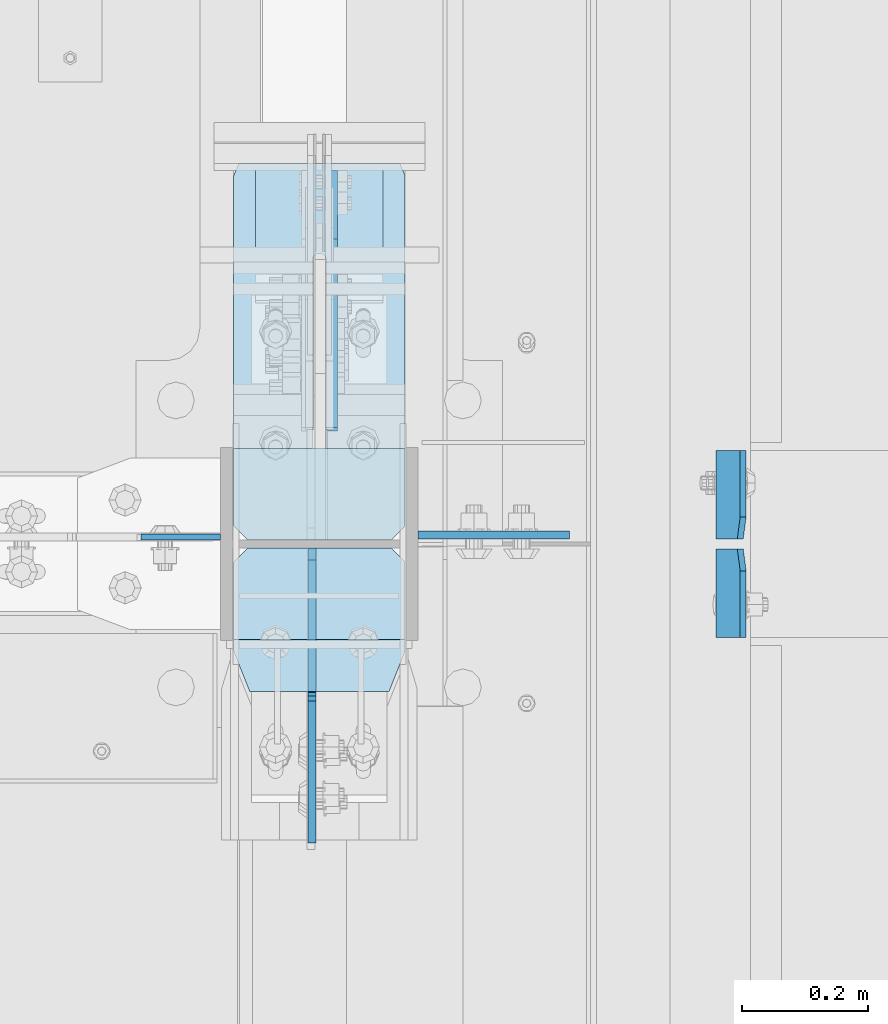
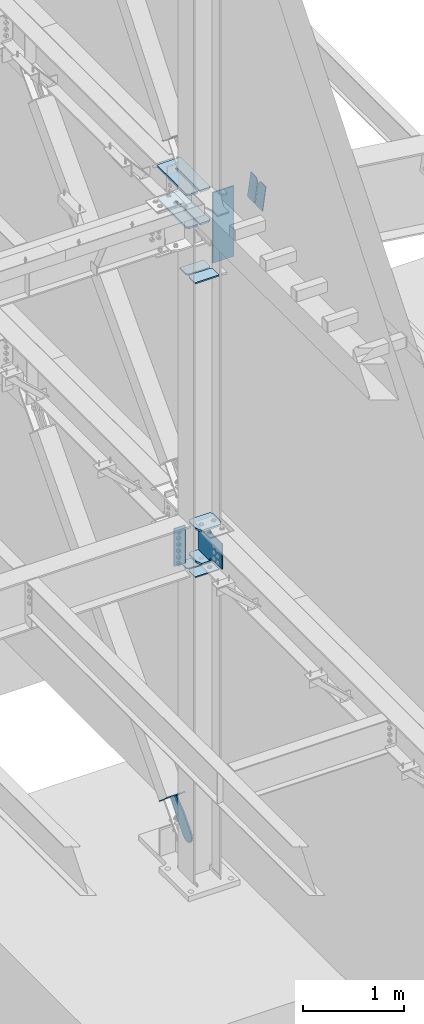
# One storey, part 1046 of 1179: 15 plates, 4 elements without a shape of their own.
"""IFC2X3 building model written with IfcOpenShell, lengths in millimetres."""

import ifcopenshell
import ifcopenshell.guid

model = None  # the IFC model being written
_history = None  # IfcOwnerHistory: only IFC2X3 demands one
_inside = {}  # id of a spatial element -> (the spatial element, [elements in it])
_under = {}  # id of a project, library or spatial element -> (it, [spatial elements below it])
_declared = {}  # id of a project -> (the project, [libraries it declares])
_typed = {}  # id of a type object -> (the type object, [elements of that type])
_made_of = {}  # id of a material, layer set ... -> (it, [elements and type objects made of it])


def new_model(schema):
    """Start an empty IFC model of exactly this schema.

    Asked for "IFC4X3", IfcOpenShell would pick the latest addendum, in which some entities
    have other attributes; the version numbers below select the first issue.
    IFC2X3 requires an IfcOwnerHistory on every rooted entity: one is made here for all.
    """
    global model, _history
    if schema == "IFC4X3":
        model = ifcopenshell.file(schema_version=(4, 3, 0, 0))
    else:
        model = ifcopenshell.file(schema=schema)
    _inside.clear()
    _under.clear()
    _declared.clear()
    _typed.clear()
    _made_of.clear()
    _history = None
    if model.schema == "IFC2X3":
        org = make("IfcOrganization", Name="unknown")
        user = make(
            "IfcPersonAndOrganization",
            ThePerson=make("IfcPerson", FamilyName="unknown"),
            TheOrganization=org,
        )
        app = make(
            "IfcApplication",
            ApplicationDeveloper=org,
            Version="unknown",
            ApplicationFullName="unknown",
            ApplicationIdentifier="unknown",
        )
        _history = make(
            "IfcOwnerHistory",
            OwningUser=user,
            OwningApplication=app,
            ChangeAction="ADDED",
            CreationDate=0,
        )
    return model


def make(cls, **values):
    """One entity of the class cls with the attributes given. An attribute that is None is left unset."""
    return model.create_entity(
        cls, **{name: value for name, value in values.items() if value is not None}
    )


def rooted(cls, **values):
    """An entity with a GlobalId (a new one), such as an element, a storey or a relation."""
    return make(cls, GlobalId=ifcopenshell.guid.new(), OwnerHistory=_history, **values)


def si_unit(unit_type, name, prefix=None):
    """IfcSIUnit, for example si_unit("LENGTHUNIT", "METRE", prefix="MILLI")."""
    return make("IfcSIUnit", UnitType=unit_type, Prefix=prefix, Name=name)


def assignment(units):
    """IfcUnitAssignment: the units of a project."""
    return None if units is None else make("IfcUnitAssignment", Units=units)


def point(xyz):
    """IfcCartesianPoint."""
    return None if xyz is None else make("IfcCartesianPoint", Coordinates=xyz)


def direction(xyz):
    """IfcDirection."""
    return None if xyz is None else make("IfcDirection", DirectionRatios=xyz)


def frame(location, z_axis=None, x_axis=None):
    """IfcAxis2Placement3D, a coordinate frame: its origin and axes. An axis left out is left unset."""
    return make(
        "IfcAxis2Placement3D",
        Location=point(location),
        Axis=direction(z_axis),
        RefDirection=direction(x_axis),
    )


def origin_with_axes():
    """The frame at (0, 0, 0) with the z axis (0, 0, 1) and the x axis (1, 0, 0) written out."""
    return frame((0.0, 0.0, 0.0), z_axis=(0.0, 0.0, 1.0), x_axis=(1.0, 0.0, 0.0))


def place(relative_to, where):
    """IfcLocalPlacement: puts the frame where relative to a parent placement (None: the world)."""
    return make(
        "IfcLocalPlacement", PlacementRelTo=relative_to, RelativePlacement=where
    )


def context(
    kind, dimensions, precision=None, world=None, true_north=None, identifier=None
):
    """IfcGeometricRepresentationContext, for example the 3D "Model" context."""
    return make(
        "IfcGeometricRepresentationContext",
        ContextIdentifier=identifier,
        ContextType=kind,
        CoordinateSpaceDimension=dimensions,
        Precision=precision,
        WorldCoordinateSystem=world,
        TrueNorth=true_north,
    )


def subcontext(parent, identifier, kind, view, scale=None):
    """IfcGeometricRepresentationSubContext, for example "Body" below "Model"."""
    return make(
        "IfcGeometricRepresentationSubContext",
        ContextIdentifier=identifier,
        ContextType=kind,
        ParentContext=parent,
        TargetScale=scale,
        TargetView=view,
    )


def project(units=None, contexts=None):
    """IfcProject with its units and contexts."""
    return rooted(
        "IfcProject",
        Name="project",
        RepresentationContexts=contexts,
        UnitsInContext=assignment(units),
    )


def spatial(cls, under=None, at=None, **own):
    """A site, building, storey or space (cls), placed at a placement, below another one or the project."""
    s = rooted(cls, ObjectPlacement=at, **own)
    if under is not None:
        _under.setdefault(under.id(), (under, []))[1].append(s)
    return s


def faces_of(points, faces, orient=None, outer=None):
    """IfcFace entities. A face is a list of loops; a loop is a list of indices into points, from 0.

    orient and outer hold one flag for each loop. By default every Orientation is true, the
    first loop of a face is its IfcFaceOuterBound and the others are IfcFaceBound.
    """
    made = []
    for i, loops in enumerate(faces):
        bounds = []
        for j, loop in enumerate(loops):
            is_outer = j == 0 if outer is None else outer[i][j]
            bounds.append(
                make(
                    "IfcFaceOuterBound" if is_outer else "IfcFaceBound",
                    Bound=make("IfcPolyLoop", Polygon=[points[k] for k in loop]),
                    Orientation=True if orient is None else orient[i][j],
                )
            )
        made.append(make("IfcFace", Bounds=bounds))
    return made


def faceted_brep(points, faces, orient=None, outer=None, voids=None):
    """IfcFacetedBrep: a solid bounded by flat faces; with voids (closed shells), ...WithVoids."""
    shared = [point(p) for p in points]
    hull = make("IfcClosedShell", CfsFaces=faces_of(shared, faces, orient, outer))
    if voids is None:
        return make("IfcFacetedBrep", Outer=hull)
    return make(
        "IfcFacetedBrepWithVoids",
        Outer=hull,
        Voids=[
            make(cls, CfsFaces=faces_of(shared, fs, o, b)) for cls, fs, o, b in voids
        ],
    )


def shape(context_of_items, identifier, shape_type, items):
    """IfcShapeRepresentation: the items that make up one representation, for example the "Body"."""
    return make(
        "IfcShapeRepresentation",
        ContextOfItems=context_of_items,
        RepresentationIdentifier=identifier,
        RepresentationType=shape_type,
        Items=items,
    )


def material(Name=None, Category=None):
    """IfcMaterial."""
    return make("IfcMaterial", Name=Name, Category=Category)


def made_of(thing, what):
    """Note that an element or type object is made of a material, layer set ...; save() writes the relation."""
    if what is not None:
        _made_of.setdefault(what.id(), (what, []))[1].append(thing)
    return thing


def type_object(cls, material=None, **own):
    """A type object (cls), such as IfcWallType, which elements share."""
    return made_of(rooted(cls, **own), material)


def element(
    cls,
    number,
    at=None,
    inside=None,
    cuts=None,
    type_object=None,
    material=None,
    context=None,
    identifier="Body",
    shape_type=None,
    held_by="IfcProductDefinitionShape",
    body=None,
    shapes=None,
    **own,
):
    """One element of the class cls, such as IfcWall. Its Tag is "e" and its number.

    at: its placement. inside: the storey or other place that contains it. cuts: it is an
    opening in that element (IfcRelVoidsElement). A single representation is given by context,
    identifier, shape_type and body (its items); several are given by shapes. held_by: the class
    of the entity that holds the representations. save() writes the other relations.
    """
    e = rooted(cls, Tag="e%d" % number, ObjectPlacement=at, **own)
    if body is not None:
        shapes = [shape(context, identifier, shape_type, body)]
    if shapes is not None:
        e.Representation = make(held_by, Representations=shapes)
    if inside is not None:
        _inside.setdefault(inside.id(), (inside, []))[1].append(e)
    if cuts is not None:
        rooted(
            "IfcRelVoidsElement", RelatingBuildingElement=cuts, RelatedOpeningElement=e
        )
    if type_object is not None:
        _typed.setdefault(type_object.id(), (type_object, []))[1].append(e)
    return made_of(e, material)


def aggregate(whole, parts):
    """IfcRelAggregates: a whole, such as a stair, and the parts it consists of."""
    return rooted("IfcRelAggregates", RelatingObject=whole, RelatedObjects=parts)


def save(model, path):
    """Write the relations noted so far, then the file.

    IfcRelAggregates (storeys below a building ...), IfcRelContainedInSpatialStructure (elements
    in a storey), IfcRelDefinesByType, IfcRelAssociatesMaterial and IfcRelDeclares: one each for
    every whole, place, type object, material and project.
    """
    for whole, parts in _under.values():
        aggregate(whole, parts)
    for where, things in _inside.values():
        rooted(
            "IfcRelContainedInSpatialStructure",
            RelatedElements=things,
            RelatingStructure=where,
        )
    for kind, things in _typed.values():
        rooted("IfcRelDefinesByType", RelatedObjects=things, RelatingType=kind)
    for what, things in _made_of.values():
        rooted("IfcRelAssociatesMaterial", RelatedObjects=things, RelatingMaterial=what)
    for by, libraries in _declared.values():
        rooted("IfcRelDeclares", RelatingContext=by, RelatedDefinitions=libraries)
    model.write(path)


model = new_model("IFC2X3")

# Units and contexts
model_context = context("Model", 3, precision=1e-05, world=origin_with_axes())
body_context = subcontext(model_context, "Body", "Model", "MODEL_VIEW")
ifc_project = project(units=[si_unit("LENGTHUNIT", "METRE", prefix="MILLI"), si_unit("AREAUNIT", "SQUARE_METRE"), si_unit("VOLUMEUNIT", "CUBIC_METRE"), si_unit("MASSUNIT", "GRAM", prefix="KILO"), si_unit("TIMEUNIT", "SECOND"), si_unit("PLANEANGLEUNIT", "RADIAN"), si_unit("SOLIDANGLEUNIT", "STERADIAN"), si_unit("THERMODYNAMICTEMPERATUREUNIT", "DEGREE_CELSIUS"), si_unit("LUMINOUSINTENSITYUNIT", "LUMEN")], contexts=[model_context])

# Site, building, storey
site_placement = place(None, origin_with_axes())
site = spatial("IfcSite", under=ifc_project, at=site_placement, CompositionType="ELEMENT")
building_placement = place(site_placement, origin_with_axes())
building = spatial("IfcBuilding", under=site, at=building_placement, Name="Undefined", CompositionType="ELEMENT")
storey_placement = place(building_placement, origin_with_axes())
storey = spatial("IfcBuildingStorey", under=building, at=storey_placement, Name="Undefined", CompositionType="ELEMENT", Elevation=0.0)

# Assembly, plates
assembly_1_placement = place(storey_placement, origin_with_axes())
assembly_1 = element("IfcElementAssembly", 1, at=assembly_1_placement, inside=storey, Name="COLUMN", AssemblyPlace="NOTDEFINED", PredefinedType="RIGID_FRAME")
ifc_material_1 = material(Name="STEEL/A36")
plate_type_1 = type_object("IfcPlateType", PredefinedType="NOTDEFINED")
plate_1_placement = place(assembly_1_placement, frame((24150.6375, 27062.1125, 4038.6), z_axis=(-1.0, 0.0, 0.0), x_axis=(0.0, 0.0, -1.0)))
plate_1 = element("IfcPlate", 2, at=plate_1_placement, type_object=plate_type_1, material=ifc_material_1, Name="PLATE", context=body_context, shape_type="Brep", body=[
    faceted_brep([(0.0, -4.76249999999709, 0.0), (0.0, -4.76249999999709, 127.0), (0.0, 4.76249999999709, 127.0), (0.0, 4.76249999999709, 0.0), (457.200012207031, -4.76250000000073, 127.0), (457.200012207031, 4.76250000000073, 127.0), (457.200012207031, -4.76250000000073, 0.0), (457.200012207031, 4.76250000000073, 0.0)], [[[0, 1, 2, 3]], [[1, 4, 5, 2]], [[4, 6, 7, 5]], [[6, 0, 3, 7]], [[5, 7, 3, 2]], [[6, 4, 1, 0]]]),
])
ifc_material_2 = material(Name="STEEL/A572-GR.50")
plate_type_2 = type_object("IfcPlateType", PredefinedType="NOTDEFINED")
plate_2_placement = place(assembly_1_placement, frame((24171.2749938965, 27656.8088209119, 7605.7125), z_axis=(0.0, -1.0, 0.0), x_axis=(1.0, 0.0, 0.0)))
plate_2 = element("IfcPlate", 3, at=plate_2_placement, type_object=plate_type_2, material=ifc_material_2, Name="PLATE", context=body_context, shape_type="Brep", body=[
    faceted_brep([(125.412506103512, -11.1125000000002, 599.458820911852), (125.412487792968, -11.1125000000002, 153.987500190735), (125.412487792968, 11.1125000000002, 153.987500190735), (125.412506103512, 11.1125000000002, 599.458820911852), (126.258376502454, -11.1125000000002, 149.734930475586), (126.258376502454, 11.1125000000002, 149.734930475586), (128.667263742896, -11.1125000000002, 146.12977594993), (128.667263742896, 11.1125000000002, 146.12977594993), (132.272418268556, -11.1125000000002, 143.720888709488), (132.272418268556, 11.1125000000002, 143.720888709488), (136.524987602239, -11.1125000000002, 142.875), (136.524987602239, 11.1125000000002, 142.875), (140.777557317386, -11.1125000000002, 143.720888709488), (140.777557317386, 11.1125000000002, 143.720888709488), (144.382711843045, -11.1125000000002, 146.12977594993), (144.382711843045, 11.1125000000002, 146.12977594993), (146.791599083488, -11.1125000000002, 149.734930475586), (146.791599083488, 11.1125000000002, 149.734930475586), (147.637487792974, -11.1125000000002, 153.987500190735), (147.637487792974, 11.1125000000002, 153.987500190735), (147.637506103518, -11.1125000000002, 599.458820911852), (147.637506103518, 11.1125000000002, 599.458820911852), (0.0, -11.1125000000002, 577.233820530382), (22.2250003814697, -11.1125000000002, 599.458820911852), (22.2250003814697, 11.1125000000002, 599.458820911852), (0.0, 11.1125000000002, 577.233820530382), (0.0, -11.1125000000002, 19.0499992370605), (0.0, 11.1125000000002, 19.0499992370605), (7.9375, -11.1125000000002, 0.0), (7.9375, 11.1125000000002, 0.0), (265.112506103513, -11.1125000000002, 0.0), (265.112506103513, 11.1125000000002, 0.0), (273.050006103513, -11.1125000000002, 19.0499992370605), (273.050006103513, 11.1125000000002, 19.0499992370605), (273.050006103513, -11.1125000000002, 577.233820530382), (273.050006103513, 11.1125000000002, 577.233820530382), (250.825005722043, -11.1125000000002, 599.458820911852), (250.825005722043, 11.1125000000002, 599.458820911852)], [[[0, 1, 2, 3]], [[4, 5, 2, 1]], [[6, 7, 5, 4]], [[8, 9, 7, 6]], [[10, 11, 9, 8]], [[12, 13, 11, 10]], [[14, 15, 13, 12]], [[16, 17, 15, 14]], [[18, 19, 17, 16]], [[20, 21, 19, 18]], [[22, 23, 24, 25]], [[26, 22, 25, 27]], [[28, 26, 27, 29]], [[30, 28, 29, 31]], [[32, 30, 31, 33]], [[34, 32, 33, 35]], [[36, 34, 35, 37]], [[16, 14, 12, 10, 8, 6, 4, 1, 0, 23, 22, 26, 28, 30, 32, 34, 36, 20, 18]], [[24, 23, 0, 3]], [[37, 35, 33, 31, 29, 27, 25, 24, 3, 2, 5, 7, 9, 11, 13, 15, 17, 19, 21]], [[36, 37, 21, 20]]]),
])
plate_3_placement = place(assembly_1_placement, frame((24171.2749938965, 27656.8088209119, 8002.5875), z_axis=(0.0, -1.0, 0.0), x_axis=(1.0, 0.0, 0.0)))
plate_3 = element("IfcPlate", 4, at=plate_3_placement, type_object=plate_type_2, material=ifc_material_2, Name="PLATE", context=body_context, shape_type="Brep", body=[
    faceted_brep([(125.412506103512, -11.1125000000002, 599.458820911852), (125.412487792968, -11.1125000000002, 153.987500190735), (125.412487792968, 11.1125000000002, 153.987500190735), (125.412506103512, 11.1125000000002, 599.458820911852), (126.258376502454, -11.1125000000002, 149.734930475586), (126.258376502454, 11.1125000000002, 149.734930475586), (128.667263742896, -11.1125000000002, 146.12977594993), (128.667263742896, 11.1125000000002, 146.12977594993), (132.272418268556, -11.1125000000002, 143.720888709488), (132.272418268556, 11.1125000000002, 143.720888709488), (136.524987602239, -11.1125000000002, 142.875), (136.524987602239, 11.1125000000002, 142.875), (140.777557317386, -11.1125000000002, 143.720888709488), (140.777557317386, 11.1125000000002, 143.720888709488), (144.382711843045, -11.1125000000002, 146.12977594993), (144.382711843045, 11.1125000000002, 146.12977594993), (146.791599083488, -11.1125000000002, 149.734930475586), (146.791599083488, 11.1125000000002, 149.734930475586), (147.637487792974, -11.1125000000002, 153.987500190735), (147.637487792974, 11.1125000000002, 153.987500190735), (147.637506103518, -11.1125000000002, 599.458820911852), (147.637506103518, 11.1125000000002, 599.458820911852), (0.0, -11.1125000000002, 577.233820530382), (22.2250003814697, -11.1125000000002, 599.458820911852), (22.2250003814697, 11.1125000000002, 599.458820911852), (0.0, 11.1125000000002, 577.233820530382), (0.0, -11.1125000000002, 19.0499992370605), (0.0, 11.1125000000002, 19.0499992370605), (7.9375, -11.1125000000002, 0.0), (7.9375, 11.1125000000002, 0.0), (265.112506103513, -11.1125000000002, 0.0), (265.112506103513, 11.1125000000002, 0.0), (273.050006103513, -11.1125000000002, 19.0499992370605), (273.050006103513, 11.1125000000002, 19.0499992370605), (273.050006103513, -11.1125000000002, 577.233820530382), (273.050006103513, 11.1125000000002, 577.233820530382), (250.825005722043, -11.1125000000002, 599.458820911852), (250.825005722043, 11.1125000000002, 599.458820911852)], [[[0, 1, 2, 3]], [[4, 5, 2, 1]], [[6, 7, 5, 4]], [[8, 9, 7, 6]], [[10, 11, 9, 8]], [[12, 13, 11, 10]], [[14, 15, 13, 12]], [[16, 17, 15, 14]], [[18, 19, 17, 16]], [[20, 21, 19, 18]], [[22, 23, 24, 25]], [[26, 22, 25, 27]], [[28, 26, 27, 29]], [[30, 28, 29, 31]], [[32, 30, 31, 33]], [[34, 32, 33, 35]], [[36, 34, 35, 37]], [[16, 14, 12, 10, 8, 6, 4, 1, 0, 23, 22, 26, 28, 30, 32, 34, 36, 20, 18]], [[24, 23, 0, 3]], [[37, 35, 33, 31, 29, 27, 25, 24, 3, 2, 5, 7, 9, 11, 13, 15, 17, 19, 21]], [[36, 37, 21, 20]]]),
])

assembly_2_placement = place(storey_placement, origin_with_axes())
assembly_2 = element("IfcElementAssembly", 5, at=assembly_2_placement, inside=storey, Name="BEAM", AssemblyPlace="NOTDEFINED", PredefinedType="RIGID_FRAME")
plate_type_3 = type_object("IfcPlateType", PredefinedType="NOTDEFINED")
plate_4_placement = place(assembly_2_placement, frame((24982.9723149444, 27058.9375, 7924.64444967863), z_axis=(0.0, 1.0, 0.0), x_axis=(-0.133813222971046, 0.0, -0.991006569785539)))
plate_4 = element("IfcPlate", 6, at=plate_4_placement, type_object=plate_type_3, material=ifc_material_1, Name="PLATE", context=body_context, shape_type="Brep", body=[
    faceted_brep([(0.0, -4.76250000000073, 34.9249999999993), (0.0, -4.76250000001164, 141.287499999999), (-3.63797880709171e-12, 4.76249999998981, 141.287499999999), (0.0, 4.76250000000073, 34.9249999999993), (290.512500000297, -4.76249999966967, 141.287499999999), (290.512500000294, 4.76250000033906, 141.287499999999), (290.512500000297, -4.76249999966967, 0.0), (290.512500000294, 4.76250000033906, 0.0), (34.9249992370715, -4.76249999996799, 0.0), (34.9249992370678, 4.76250000003347, 0.0)], [[[0, 1, 2, 3]], [[1, 4, 5, 2]], [[4, 6, 7, 5]], [[6, 8, 9, 7]], [[8, 0, 3, 9]], [[5, 7, 9, 3, 2]], [[8, 6, 4, 1, 0]]]),
])
plate_5_placement = place(assembly_2_placement, frame((24982.9723149444, 27043.0625, 7924.64444967849), z_axis=(0.0, -1.0, 0.0), x_axis=(-0.133813222971046, 0.0, -0.991006569785539)))
plate_5 = element("IfcPlate", 7, at=plate_5_placement, type_object=plate_type_3, material=ifc_material_1, Name="PLATE", context=body_context, shape_type="Brep", body=[
    faceted_brep([(0.0, -4.76250000000073, 34.9249999999993), (0.0, -4.76250000001164, 141.287499999999), (-3.63797880709171e-12, 4.76249999998981, 141.287499999999), (0.0, 4.76250000000073, 34.9249999999993), (290.512500000297, -4.76249999966967, 141.287499999999), (290.512500000294, 4.76250000033906, 141.287499999999), (290.512500000297, -4.76249999966967, 0.0), (290.512500000294, 4.76250000033906, 0.0), (34.9249992370715, -4.76249999996799, 0.0), (34.9249992370678, 4.76250000003347, 0.0)], [[[0, 1, 2, 3]], [[1, 4, 5, 2]], [[4, 6, 7, 5]], [[6, 8, 9, 7]], [[8, 0, 3, 9]], [[5, 7, 9, 3, 2]], [[8, 6, 4, 1, 0]]]),
])
aggregate(assembly_2, [plate_4, plate_5])

# Assembly, plate
assembly_3_placement = place(storey_placement, origin_with_axes())
assembly_3 = element("IfcElementAssembly", 8, at=assembly_3_placement, inside=storey, Name="Plate", AssemblyPlace="NOTDEFINED", PredefinedType="RIGID_FRAME")
plate_type_4 = type_object("IfcPlateType", PredefinedType="NOTDEFINED")
plate_6_placement = place(assembly_3_placement, frame((24409.4, 27665.0983331715, 319.005906308155), z_axis=(0.0, -0.74575357167811, 0.666221892712438), x_axis=(-1.0, 0.0, 0.0)))
plate_6 = element("IfcPlate", 9, at=plate_6_placement, type_object=plate_type_4, material=ifc_material_1, Name="Plate", context=body_context, shape_type="Brep", body=[
    faceted_brep([(0.0, -3.17500000000109, 0.0), (0.0, -3.17500000000291, 203.200000000368), (0.0, 3.17499999998836, 203.200000000361), (0.0, 3.17500000000109, 7.27595761418343e-12), (203.199999999997, -3.17500000000291, 203.200000000368), (203.199999999997, 3.17499999998836, 203.200000000361), (203.199999999997, -3.17499999999927, 3.63797880709171e-12), (203.199999999997, 3.17499999999382, -3.63797880709171e-12)], [[[0, 1, 2, 3]], [[1, 4, 5, 2]], [[4, 6, 7, 5]], [[6, 0, 3, 7]], [[5, 7, 3, 2]], [[6, 4, 1, 0]]]),
])
aggregate(assembly_3, [plate_6])

# Plate
plate_type_5 = type_object("IfcPlateType", PredefinedType="NOTDEFINED")
plate_7_placement = place(assembly_1_placement, frame((24171.275, 26816.05, 3694.1125), z_axis=(1.0, 0.0, 0.0), x_axis=(0.0, 1.0, 0.0)))
plate_7 = element("IfcPlate", 10, at=plate_7_placement, type_object=plate_type_5, material=ifc_material_2, Name="PLATE", context=body_context, shape_type="Brep", body=[
    faceted_brep([(0.0, -11.1125000000002, 247.650000381473), (63.5, -11.1125000000002, 273.050000000003), (63.5, 11.1125000000002, 273.050000000003), (0.0, 11.1125000000002, 247.650000381473), (63.5, -11.1125000000002, 0.0), (0.0, -11.1125000000002, 25.3999996185303), (0.0, 11.1125000000002, 25.3999996185303), (63.5, 11.1125000000002, 0.0), (206.374999618529, -11.1125000000002, 0.0), (206.374999618529, 11.1125000000002, 0.0), (228.599999999999, -11.1125000000002, 22.2250003814697), (228.599999999999, 11.1125000000002, 22.2250003814697), (228.599999999999, -11.1125000000002, 250.824999618533), (228.599999999999, 11.1125000000002, 250.824999618533), (206.374999618529, -11.1125000000002, 273.050000000003), (206.374999618529, 11.1125000000002, 273.050000000003)], [[[0, 1, 2, 3]], [[4, 5, 6, 7]], [[8, 4, 7, 9]], [[10, 8, 9, 11]], [[12, 10, 11, 13]], [[14, 12, 13, 15]], [[4, 8, 10, 12, 14, 1, 0, 5]], [[5, 0, 3, 6]], [[2, 15, 13, 11, 9, 7, 6, 3]], [[1, 14, 15, 2]]]),
])

plate_8_placement = place(assembly_1_placement, frame((24171.275, 26816.05, 4090.9875), z_axis=(1.0, 0.0, 0.0), x_axis=(0.0, 1.0, 0.0)))
plate_8 = element("IfcPlate", 11, at=plate_8_placement, type_object=plate_type_5, material=ifc_material_2, Name="PLATE", context=body_context, shape_type="Brep", body=[
    faceted_brep([(0.0, -11.1125000000002, 247.650000381473), (63.5, -11.1125000000002, 273.050000000003), (63.5, 11.1125000000002, 273.050000000003), (0.0, 11.1125000000002, 247.650000381473), (63.5, -11.1125000000002, 0.0), (0.0, -11.1125000000002, 25.3999996185303), (0.0, 11.1125000000002, 25.3999996185303), (63.5, 11.1125000000002, 0.0), (206.374999618529, -11.1125000000002, 0.0), (206.374999618529, 11.1125000000002, 0.0), (228.599999999999, -11.1125000000002, 22.2250003814697), (228.599999999999, 11.1125000000002, 22.2250003814697), (228.599999999999, -11.1125000000002, 250.824999618533), (228.599999999999, 11.1125000000002, 250.824999618533), (206.374999618529, -11.1125000000002, 273.050000000003), (206.374999618529, 11.1125000000002, 273.050000000003)], [[[0, 1, 2, 3]], [[4, 5, 6, 7]], [[8, 4, 7, 9]], [[10, 8, 9, 11]], [[12, 10, 11, 13]], [[14, 12, 13, 15]], [[4, 8, 10, 12, 14, 1, 0, 5]], [[5, 0, 3, 6]], [[2, 15, 13, 11, 9, 7, 6, 3]], [[1, 14, 15, 2]]]),
])

plate_type_6 = type_object("IfcPlateType", PredefinedType="NOTDEFINED")
plate_9_placement = place(assembly_1_placement, frame((24444.325, 27044.65, 3495.675), z_axis=(-1.0, 0.0, 0.0), x_axis=(0.0, -1.0, 0.0)))
plate_9 = element("IfcPlate", 12, at=plate_9_placement, type_object=plate_type_6, material=ifc_material_1, Name="PLATE", context=body_context, shape_type="Brep", body=[
    faceted_brep([(0.0, -6.34999999999854, 22.2250003814697), (0.0, -6.35000000000036, 250.82499961853), (0.0, 6.35000000000036, 250.82499961853), (0.0, 6.34999999999854, 22.2250003814697), (22.2250003814697, -6.35000000000036, 273.05), (22.2250003814697, 6.35000000000036, 273.05), (146.050003051758, -6.35000000000036, 273.049987792969), (146.050003051758, 6.35000000000036, 273.049987792969), (146.050003051758, -6.35000000000036, 0.0), (146.050003051758, 6.35000000000036, 0.0), (22.2250003814697, -6.34999999999854, 0.0), (22.2250003814697, 6.34999999999854, 0.0)], [[[0, 1, 2, 3]], [[1, 4, 5, 2]], [[4, 6, 7, 5]], [[6, 8, 9, 7]], [[8, 10, 11, 9]], [[10, 0, 3, 11]], [[5, 7, 9, 11, 3, 2]], [[10, 8, 6, 4, 1, 0]]]),
])

plate_10_placement = place(assembly_1_placement, frame((24444.325, 27203.4, 3495.675), z_axis=(-1.0, 0.0, 0.0), x_axis=(0.0, -1.0, 0.0)))
plate_10 = element("IfcPlate", 13, at=plate_10_placement, type_object=plate_type_6, material=ifc_material_1, Name="PLATE", context=body_context, shape_type="Brep", body=[
    faceted_brep([(0.0, -6.34999999999854, 0.0), (0.0, -6.34999999999991, 273.05), (0.0, 6.34999999999991, 273.05), (0.0, 6.34999999999854, 0.0), (123.824999618599, -6.34999999999991, 273.05), (123.824999618599, 6.34999999999991, 273.05), (146.050000000068, -6.34999999999991, 250.82499961853), (146.050000000068, 6.34999999999991, 250.82499961853), (146.050000000068, -6.34999999999991, 22.2250003814697), (146.050000000068, 6.34999999999991, 22.2250003814697), (123.824999618599, -6.34999999999991, 0.0), (123.824999618599, 6.34999999999991, 0.0)], [[[0, 1, 2, 3]], [[1, 4, 5, 2]], [[4, 6, 7, 5]], [[6, 8, 9, 7]], [[8, 10, 11, 9]], [[10, 0, 3, 11]], [[5, 7, 9, 11, 3, 2]], [[10, 8, 6, 4, 1, 0]]]),
])

plate_type_7 = type_object("IfcPlateType", PredefinedType="NOTDEFINED")
plate_11_placement = place(assembly_1_placement, frame((24444.325, 27044.65, 7041.2706389203), z_axis=(-1.0, 0.0, 0.0), x_axis=(0.0, -1.0, 0.0)))
plate_11 = element("IfcPlate", 14, at=plate_11_placement, type_object=plate_type_7, material=ifc_material_1, Name="PLATE", context=body_context, shape_type="Brep", body=[
    faceted_brep([(0.0, -7.9375, 22.2250003814697), (0.0, -7.9375, 250.824987411499), (0.0, 7.9375, 250.824987411499), (0.0, 7.9375, 22.2250003814697), (22.2250003814697, -7.9375, 273.049987792969), (22.2250003814697, 7.9375, 273.049987792969), (146.050003051758, -7.9375, 273.049987792969), (146.050003051758, 7.9375, 273.049987792969), (146.050003051758, -7.9375, 0.0), (146.050003051758, 7.9375, 0.0), (22.2250003814697, -7.9375, 0.0), (22.2250003814697, 7.9375, 0.0)], [[[0, 1, 2, 3]], [[1, 4, 5, 2]], [[4, 6, 7, 5]], [[6, 8, 9, 7]], [[8, 10, 11, 9]], [[10, 0, 3, 11]], [[5, 7, 9, 11, 3, 2]], [[10, 8, 6, 4, 1, 0]]]),
])

plate_12_placement = place(assembly_1_placement, frame((24444.325, 27203.4, 7041.2706389203), z_axis=(-1.0, 0.0, 0.0), x_axis=(0.0, -1.0, 0.0)))
plate_12 = element("IfcPlate", 15, at=plate_12_placement, type_object=plate_type_7, material=ifc_material_1, Name="PLATE", context=body_context, shape_type="Brep", body=[
    faceted_brep([(0.0, -7.9375, 0.0), (0.0, -7.9375, 273.049987792969), (0.0, 7.9375, 273.049987792969), (0.0, 7.9375, 0.0), (123.825002670288, -7.9375, 273.049987792969), (123.825002670288, 7.9375, 273.049987792969), (146.050003051758, -7.9375, 250.824987411499), (146.050003051758, 7.9375, 250.824987411499), (146.050003051758, -7.9375, 22.2250003814697), (146.050003051758, 7.9375, 22.2250003814697), (123.825002670288, -7.9375, 0.0), (123.825002670288, 7.9375, 0.0)], [[[0, 1, 2, 3]], [[1, 4, 5, 2]], [[4, 6, 7, 5]], [[6, 8, 9, 7]], [[8, 10, 11, 9]], [[10, 0, 3, 11]], [[5, 7, 9, 11, 3, 2]], [[10, 8, 6, 4, 1, 0]]]),
])

# Assembly, plate
assembly_4_placement = place(storey_placement, origin_with_axes())
assembly_4 = element("IfcElementAssembly", 16, at=assembly_4_placement, inside=storey, AssemblyPlace="NOTDEFINED", PredefinedType="RIGID_FRAME")
plate_type_8 = type_object("IfcPlateType", PredefinedType="NOTDEFINED")
plate_13_placement = place(assembly_4_placement, frame((24328.4375, 27594.6102194491, 282.352678620124), z_axis=(0.0, -0.74575357167811, 0.666221892712438), x_axis=(0.0, 0.666221892712437, 0.74575357167811)))
plate_13 = element("IfcPlate", 17, at=plate_13_placement, type_object=plate_type_8, material=ifc_material_1, context=body_context, shape_type="Brep", body=[
    faceted_brep([(0.0, -7.9375, 0.0), (-101.600000000497, -7.9375, -21.7975798445477), (-101.600000000497, 7.9375, -21.7975798445477), (0.0, 7.9375, 0.0), (-320.921138851689, -7.9375, -21.7975798443877), (-320.921138851689, 7.9375, -21.7975798443877), (-357.371735784433, -7.9375, -14.5471053160727), (-357.371735784433, 7.9375, -14.5471053160727), (-388.273059759649, -7.9375, 6.10049924760824), (-388.273059759649, 7.9375, 6.10049924760824), (-408.920664323319, -7.9375, 37.0018232228431), (-408.920664323319, 7.9375, 37.0018232228431), (-416.171138851623, -7.9375, 73.4524201546446), (-416.171138851623, 7.9375, 73.4524201546446), (-408.920664323337, -7.9375, 109.903017087447), (-408.920664323337, 7.9375, 109.903017087447), (-388.273059759656, -7.9375, 140.804341062707), (-388.273059759656, 7.9375, 140.804341062707), (-357.3717357844, -7.9375, 161.451945626395), (-357.3717357844, 7.9375, 161.451945626395), (-320.921138851201, -7.9375, 168.702420154674), (-320.921138851201, 7.9375, 168.702420154674), (-101.600000000592, -7.9375, 168.702420154521), (-101.600000000592, 7.9375, 168.702420154521), (-8.00355337560177e-11, -7.9375, 146.904840309817), (-8.00355337560177e-11, 7.9375, 146.904840309817), (77.4700000003613, -7.9375, 146.904840309813), (77.4700000003613, 7.9375, 146.904840309813), (77.4700000003904, -7.9375, -5.82076609134674e-11), (77.4700000003904, 7.9375, -5.82076609134674e-11)], [[[0, 1, 2, 3]], [[1, 4, 5, 2]], [[4, 6, 7, 5]], [[6, 8, 9, 7]], [[8, 10, 11, 9]], [[10, 12, 13, 11]], [[12, 14, 15, 13]], [[14, 16, 17, 15]], [[16, 18, 19, 17]], [[18, 20, 21, 19]], [[20, 22, 23, 21]], [[22, 24, 25, 23]], [[24, 26, 27, 25]], [[26, 28, 29, 27]], [[28, 0, 3, 29]], [[5, 7, 9, 11, 13, 15, 17, 19, 21, 23, 25, 27, 29, 3, 2]], [[28, 26, 24, 22, 20, 18, 16, 14, 12, 10, 8, 6, 4, 1, 0]]]),
])
aggregate(assembly_4, [plate_13])

# Plate
plate_type_9 = type_object("IfcPlateType", PredefinedType="NOTDEFINED")
plate_14_placement = place(assembly_1_placement, frame((24464.9625, 27065.2875, 7936.73589801268), z_axis=(1.0, 0.0, 0.0), x_axis=(0.0, 0.0, -1.0)))
plate_14 = element("IfcPlate", 18, at=plate_14_placement, type_object=plate_type_9, material=ifc_material_2, Name="PLATE", context=body_context, shape_type="Brep", body=[
    faceted_brep([(0.0, -6.34999999999854, 0.0), (0.0, -6.34999999999854, 241.300003051758), (0.0, 6.34999999999854, 241.300003051758), (0.0, 6.34999999999854, 0.0), (850.900024414062, -6.34999999999854, 241.300003051758), (850.900024414062, 6.34999999999854, 241.300003051758), (850.900024414062, -6.34999999999854, 0.0), (850.900024414062, 6.34999999999854, 0.0)], [[[0, 1, 2, 3]], [[1, 4, 5, 2]], [[4, 6, 7, 5]], [[6, 0, 3, 7]], [[5, 7, 3, 2]], [[6, 4, 1, 0]]]),
])

plate_type_10 = type_object("IfcPlateType", PredefinedType="NOTDEFINED")
plate_15_placement = place(assembly_1_placement, frame((24295.89375, 27044.6499999506, 3724.275), z_axis=(0.0, -0.707106781186506, 0.707106781186589), x_axis=(0.0, -0.70710678118659, -0.707106781186505)))
plate_15 = element("IfcPlate", 19, at=plate_15_placement, type_object=plate_type_10, material=ifc_material_2, Name="PLATE", context=body_context, shape_type="Brep", body=[
    faceted_brep([(0.0, -6.34999999999854, 0.0), (-237.976787208419, -6.34999999999854, 237.976787208414), (-237.976787208419, 6.34999999999854, 237.976787208414), (0.0, 6.34999999999854, 0.0), (-237.976787208489, -6.34999999999854, 264.917555571561), (-237.976787208489, 6.34999999999854, 264.917555571561), (-89.8025612115634, -6.34999999999854, 413.09178156849), (-89.8025612115634, 6.34999999999854, 413.09178156849), (-87.5574986365136, -6.35000000000002, 410.846713673389), (-87.5574986365136, 6.35000000000002, 410.846713673389), (-79.3171439752477, -6.34999999999854, 405.340689467515), (-79.3171439752477, 6.34999999999854, 405.340689467515), (-69.5969849391658, -6.34999999999854, 403.407229622333), (-69.5969849391658, 6.34999999999854, 403.407229622333), (-59.8768259030876, -6.34999999999854, 405.340689467494), (-59.8768259030876, 6.34999999999854, 405.340689467494), (-51.6364729667966, -6.34999999999854, 410.84671726843), (-51.6364729667966, 6.34999999999854, 410.84671726843), (101.027881360342, -6.34999999999854, 563.511071595573), (101.027881360342, 6.34999999999854, 563.511071595573), (316.554028266077, -6.34999999999854, 347.984924689843), (316.554028266077, 6.34999999999854, 347.984924689843), (163.889673938938, -6.34999999999854, 195.320570362701), (163.889673938938, 6.34999999999854, 195.320570362701), (158.383646138001, -6.34999999999854, 187.080217426408), (158.383646138001, 6.34999999999854, 187.080217426408), (156.450186292839, -6.34999999999854, 177.360058390334), (156.450186292839, 6.34999999999854, 177.360058390334), (158.383646138027, -6.34999999999854, 167.639899354248), (158.383646138027, 6.34999999999854, 167.639899354248), (163.889673938986, -6.34999999999854, 159.399546417944), (163.889673938986, 6.34999999999854, 159.399546417944), (175.114994360907, -6.34999999999854, 148.174225997692), (175.114994360907, 6.34999999999854, 148.174225997692), (26.9407683631471, -6.34999999999854, -6.91215973347425e-11), (26.9407683631471, 6.34999999999854, -6.91215973347425e-11)], [[[0, 1, 2, 3]], [[1, 4, 5, 2]], [[4, 6, 7, 5]], [[6, 8, 9, 7]], [[8, 10, 11, 9]], [[10, 12, 13, 11]], [[12, 14, 15, 13]], [[14, 16, 17, 15]], [[16, 18, 19, 17]], [[18, 20, 21, 19]], [[20, 22, 23, 21]], [[22, 24, 25, 23]], [[24, 26, 27, 25]], [[26, 28, 29, 27]], [[28, 30, 31, 29]], [[30, 32, 33, 31]], [[32, 34, 35, 33]], [[34, 0, 3, 35]], [[5, 7, 9, 11, 13, 15, 17, 19, 21, 23, 25, 27, 29, 31, 33, 35, 3, 2]], [[34, 32, 30, 28, 26, 24, 22, 20, 18, 16, 14, 12, 10, 8, 6, 4, 1, 0]]]),
])

aggregate(assembly_1, [plate_2, plate_3, plate_11, plate_12, plate_14, plate_7, plate_8, plate_15, plate_9, plate_10, plate_1])

save(model, "model.ifc")
